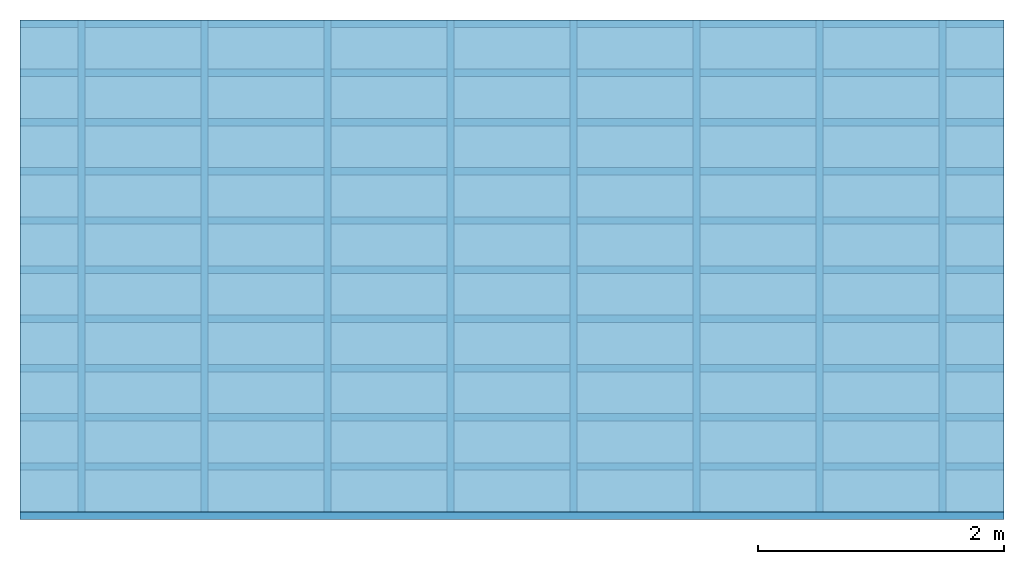
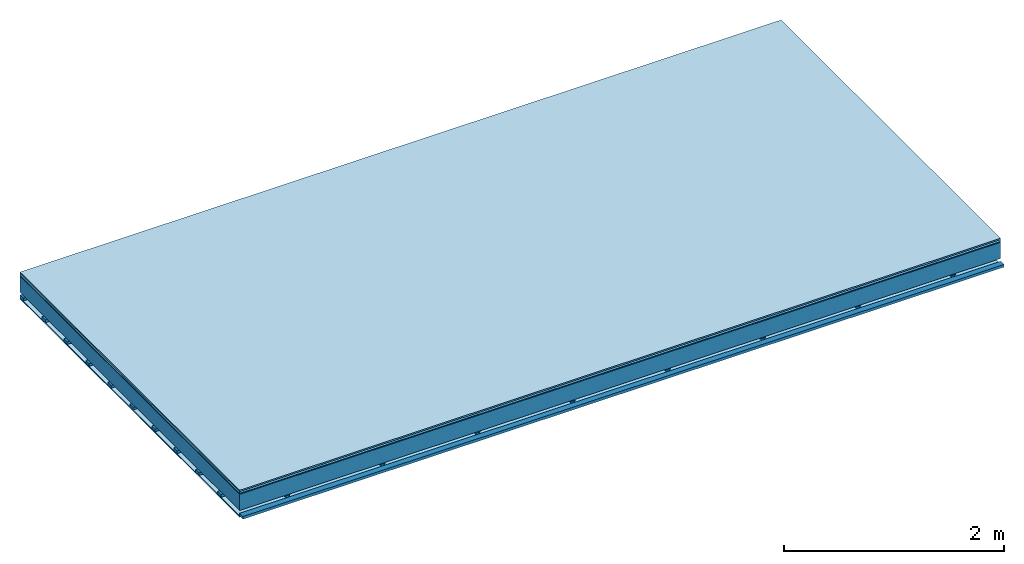
# One storey: 5 plates, 3 members, 1 element without a shape of its own.
"""IFC4 building model written with IfcOpenShell, lengths in metres."""

from ifc_helpers import new_model, si_unit, derived_unit, direction, frame, frame_2d, origin, origin_with_axes, place, context, project, spatial, polyline, rectangle, outline, extrude, material, layer, layer_set, type_object, element, aggregate, save


model = new_model("IFC4")

# Units and contexts
plan_context = context("Plan", 3, precision=1e-05, world=origin(), true_north=direction((0.0, 1.0)))
model_context = context("Model", 3, precision=1e-05, world=origin(), true_north=direction((0.0, 1.0)))
ifc_project = project(units=[si_unit("LENGTHUNIT", "METRE"), derived_unit("SOUNDPRESSUREUNIT", [(si_unit("PRESSUREUNIT", "PASCAL", prefix="MICRO"), 0)]), si_unit("ENERGYUNIT", "JOULE", prefix="MEGA"), si_unit("MASSUNIT", "GRAM", prefix="KILO"), derived_unit("THERMALTRANSMITTANCEUNIT", [(si_unit("POWERUNIT", "WATT"), 1), (si_unit("AREAUNIT", "SQUARE_METRE"), -1), (si_unit("THERMODYNAMICTEMPERATUREUNIT", "KELVIN"), -1)]), derived_unit("AREADENSITYUNIT", [(si_unit("MASSUNIT", "GRAM", prefix="KILO"), 1), (si_unit("AREAUNIT", "SQUARE_METRE"), -1)]), derived_unit("USERDEFINED", [(si_unit("ENERGYUNIT", "JOULE", prefix="MEGA"), 1), (si_unit("AREAUNIT", "SQUARE_METRE"), -1)])], contexts=[plan_context, model_context])

# Site, building, storey
site = spatial("IfcSite", under=ifc_project)
building_placement = place(None, origin())
building = spatial("IfcBuilding", under=site, at=building_placement)
storey_placement = place(building_placement, origin())
storey = spatial("IfcBuildingStorey", under=building, at=storey_placement)

# Slab, members, plates
ifc_material_1 = material(Category="11.013")
ifc_layer_1 = layer(ifc_material_1, 0.015, Name="Flooring")
ifc_material_2 = material(Category="03.007")
ifc_layer_2 = layer(ifc_material_2, 0.02, Name="On-material")
ifc_material_3 = material(Name="Wood fiber generic product", Category="10.009")
ifc_layer_3 = layer(ifc_material_3, 0.01, Name="Impact sound insulation")
ifc_material_4 = material(Name="no composite action")
ifc_layer_4 = layer(ifc_material_4, 0.0, Name="Bond")
ifc_layer_5 = layer(None, 0.18, Name="Supporting structure")
ifc_layer_6 = layer(ifc_material_4, 0.0, Name="Bond")
ifc_layer_7 = layer(None, 0.03, Name="Coupling")
ifc_layer_8 = layer(None, 0.03, Name="Battens / profiles")
ifc_material_5 = material(Name="Plasterboard type A", Category="03.008")
ifc_layer_9 = layer(ifc_material_5, 0.0125, Name="Ceiling covering 1st layer")
ifc_material_6 = material(Category="04.001")
ifc_layer_10 = layer(ifc_material_6, 0.003, Name="Surface / treatment")
ifc_layer_set = layer_set([ifc_layer_1, ifc_layer_2, ifc_layer_3, ifc_layer_4, ifc_layer_5, ifc_layer_6, ifc_layer_7, ifc_layer_8, ifc_layer_9, ifc_layer_10])
slab_type = type_object("IfcSlabType", Name="A2099", PredefinedType="NOTDEFINED", material=ifc_layer_set)
slab_placement = place(None, frame((0.0, 0.0, 0.0), z_axis=(0.0, 0.0, -1.0), x_axis=(1.0, 0.0, 0.0)))
slab = element("IfcSlab", 1, at=slab_placement, inside=storey, type_object=slab_type, material=ifc_layer_set, Name="Slab #1")
ifc_material_7 = material(Name="Solid timber panel")
member_1_placement = place(slab_placement, origin())
member_1 = element("IfcMember", 2, at=member_1_placement, material=ifc_material_7, Name="Supporting structure", context=plan_context, shape_type="SweptSolid", body=[
    extrude(rectangle(XDim=1.0, YDim=0.18, at=frame_2d((0.5, 0.09), x_axis=(1.0, 0.0))), frame((0.0, 4.0, 0.045), z_axis=(0.0, -1.0, 0.0), x_axis=(1.0, 0.0, 0.0)), (0.0, 0.0, 1.0), 4.0),
    extrude(rectangle(XDim=1.0, YDim=0.18, at=frame_2d((0.5, 0.09), x_axis=(1.0, 0.0))), frame((1.0, 4.0, 0.045), z_axis=(0.0, -1.0, 0.0), x_axis=(1.0, 0.0, 0.0)), (0.0, 0.0, 1.0), 4.0),
    extrude(rectangle(XDim=1.0, YDim=0.18, at=frame_2d((0.5, 0.09), x_axis=(1.0, 0.0))), frame((2.0, 4.0, 0.045), z_axis=(0.0, -1.0, 0.0), x_axis=(1.0, 0.0, 0.0)), (0.0, 0.0, 1.0), 4.0),
    extrude(rectangle(XDim=1.0, YDim=0.18, at=frame_2d((0.5, 0.09), x_axis=(1.0, 0.0))), frame((3.0, 4.0, 0.045), z_axis=(0.0, -1.0, 0.0), x_axis=(1.0, 0.0, 0.0)), (0.0, 0.0, 1.0), 4.0),
    extrude(rectangle(XDim=1.0, YDim=0.18, at=frame_2d((0.5, 0.09), x_axis=(1.0, 0.0))), frame((4.0, 4.0, 0.045), z_axis=(0.0, -1.0, 0.0), x_axis=(1.0, 0.0, 0.0)), (0.0, 0.0, 1.0), 4.0),
    extrude(rectangle(XDim=1.0, YDim=0.18, at=frame_2d((0.5, 0.09), x_axis=(1.0, 0.0))), frame((5.0, 4.0, 0.045), z_axis=(0.0, -1.0, 0.0), x_axis=(1.0, 0.0, 0.0)), (0.0, 0.0, 1.0), 4.0),
    extrude(rectangle(XDim=1.0, YDim=0.18, at=frame_2d((0.5, 0.09), x_axis=(1.0, 0.0))), frame((6.0, 4.0, 0.045), z_axis=(0.0, -1.0, 0.0), x_axis=(1.0, 0.0, 0.0)), (0.0, 0.0, 1.0), 4.0),
    extrude(rectangle(XDim=1.0, YDim=0.18, at=frame_2d((0.5, 0.09), x_axis=(1.0, 0.0))), frame((7.0, 4.0, 0.045), z_axis=(0.0, -1.0, 0.0), x_axis=(1.0, 0.0, 0.0)), (0.0, 0.0, 1.0), 4.0),
])
ifc_material_8 = material()
member_2_placement = place(slab_placement, origin())
member_2 = element("IfcMember", 3, at=member_2_placement, material=ifc_material_8, Name="Coupling", context=plan_context, shape_type="SweptSolid", body=[
    extrude(outline(polyline([(0.0, 0.0), (0.06, 0.0), (0.04, 0.02), (0.02, 0.02), (0.0, 0.0)])), frame((0.47, 4.0, 0.235), z_axis=(0.0, -1.0, 0.0), x_axis=(1.0, 0.0, 0.0)), (0.0, 0.0, 1.0), 4.0),
    extrude(outline(polyline([(0.0, 0.0), (0.06, 0.0), (0.04, 0.02), (0.02, 0.02), (0.0, 0.0)])), frame((1.47, 4.0, 0.235), z_axis=(0.0, -1.0, 0.0), x_axis=(1.0, 0.0, 0.0)), (0.0, 0.0, 1.0), 4.0),
    extrude(outline(polyline([(0.0, 0.0), (0.06, 0.0), (0.04, 0.02), (0.02, 0.02), (0.0, 0.0)])), frame((2.47, 4.0, 0.235), z_axis=(0.0, -1.0, 0.0), x_axis=(1.0, 0.0, 0.0)), (0.0, 0.0, 1.0), 4.0),
    extrude(outline(polyline([(0.0, 0.0), (0.06, 0.0), (0.04, 0.02), (0.02, 0.02), (0.0, 0.0)])), frame((3.47, 4.0, 0.235), z_axis=(0.0, -1.0, 0.0), x_axis=(1.0, 0.0, 0.0)), (0.0, 0.0, 1.0), 4.0),
    extrude(outline(polyline([(0.0, 0.0), (0.06, 0.0), (0.04, 0.02), (0.02, 0.02), (0.0, 0.0)])), frame((4.47, 4.0, 0.235), z_axis=(0.0, -1.0, 0.0), x_axis=(1.0, 0.0, 0.0)), (0.0, 0.0, 1.0), 4.0),
    extrude(outline(polyline([(0.0, 0.0), (0.06, 0.0), (0.04, 0.02), (0.02, 0.02), (0.0, 0.0)])), frame((5.47, 4.0, 0.235), z_axis=(0.0, -1.0, 0.0), x_axis=(1.0, 0.0, 0.0)), (0.0, 0.0, 1.0), 4.0),
    extrude(outline(polyline([(0.0, 0.0), (0.06, 0.0), (0.04, 0.02), (0.02, 0.02), (0.0, 0.0)])), frame((6.47, 4.0, 0.235), z_axis=(0.0, -1.0, 0.0), x_axis=(1.0, 0.0, 0.0)), (0.0, 0.0, 1.0), 4.0),
    extrude(outline(polyline([(0.0, 0.0), (0.06, 0.0), (0.04, 0.02), (0.02, 0.02), (0.0, 0.0)])), frame((7.47, 4.0, 0.235), z_axis=(0.0, -1.0, 0.0), x_axis=(1.0, 0.0, 0.0)), (0.0, 0.0, 1.0), 4.0),
])
member_3_placement = place(slab_placement, origin())
member_3 = element("IfcMember", 4, at=member_3_placement, material=ifc_material_8, Name="Battens / profiles", context=plan_context, shape_type="SweptSolid", body=[
    extrude(rectangle(XDim=0.06, YDim=0.03, at=frame_2d((0.03, 0.015), x_axis=(1.0, 0.0))), frame((0.0, 0.0, 0.255), z_axis=(1.0, 0.0, 0.0), x_axis=(0.0, 1.0, 0.0)), (0.0, 0.0, 1.0), 8.0),
    extrude(rectangle(XDim=0.06, YDim=0.03, at=frame_2d((0.03, 0.015), x_axis=(1.0, 0.0))), frame((0.0, 0.4, 0.255), z_axis=(1.0, 0.0, 0.0), x_axis=(0.0, 1.0, 0.0)), (0.0, 0.0, 1.0), 8.0),
    extrude(rectangle(XDim=0.06, YDim=0.03, at=frame_2d((0.03, 0.015), x_axis=(1.0, 0.0))), frame((0.0, 0.8, 0.255), z_axis=(1.0, 0.0, 0.0), x_axis=(0.0, 1.0, 0.0)), (0.0, 0.0, 1.0), 8.0),
    extrude(rectangle(XDim=0.06, YDim=0.03, at=frame_2d((0.03, 0.015), x_axis=(1.0, 0.0))), frame((0.0, 1.2, 0.255), z_axis=(1.0, 0.0, 0.0), x_axis=(0.0, 1.0, 0.0)), (0.0, 0.0, 1.0), 8.0),
    extrude(rectangle(XDim=0.06, YDim=0.03, at=frame_2d((0.03, 0.015), x_axis=(1.0, 0.0))), frame((0.0, 1.6, 0.255), z_axis=(1.0, 0.0, 0.0), x_axis=(0.0, 1.0, 0.0)), (0.0, 0.0, 1.0), 8.0),
    extrude(rectangle(XDim=0.06, YDim=0.03, at=frame_2d((0.03, 0.015), x_axis=(1.0, 0.0))), frame((0.0, 2.0, 0.255), z_axis=(1.0, 0.0, 0.0), x_axis=(0.0, 1.0, 0.0)), (0.0, 0.0, 1.0), 8.0),
    extrude(rectangle(XDim=0.06, YDim=0.03, at=frame_2d((0.03, 0.015), x_axis=(1.0, 0.0))), frame((0.0, 2.4, 0.255), z_axis=(1.0, 0.0, 0.0), x_axis=(0.0, 1.0, 0.0)), (0.0, 0.0, 1.0), 8.0),
    extrude(rectangle(XDim=0.06, YDim=0.03, at=frame_2d((0.03, 0.015), x_axis=(1.0, 0.0))), frame((0.0, 2.8, 0.255), z_axis=(1.0, 0.0, 0.0), x_axis=(0.0, 1.0, 0.0)), (0.0, 0.0, 1.0), 8.0),
    extrude(rectangle(XDim=0.06, YDim=0.03, at=frame_2d((0.03, 0.015), x_axis=(1.0, 0.0))), frame((0.0, 3.2, 0.255), z_axis=(1.0, 0.0, 0.0), x_axis=(0.0, 1.0, 0.0)), (0.0, 0.0, 1.0), 8.0),
    extrude(rectangle(XDim=0.06, YDim=0.03, at=frame_2d((0.03, 0.015), x_axis=(1.0, 0.0))), frame((0.0, 3.6, 0.255), z_axis=(1.0, 0.0, 0.0), x_axis=(0.0, 1.0, 0.0)), (0.0, 0.0, 1.0), 8.0),
    extrude(rectangle(XDim=0.06, YDim=0.03, at=frame_2d((0.03, 0.015), x_axis=(1.0, 0.0))), frame((0.0, 4.0, 0.255), z_axis=(1.0, 0.0, 0.0), x_axis=(0.0, 1.0, 0.0)), (0.0, 0.0, 1.0), 8.0),
])
plate_1_placement = place(slab_placement, origin())
plate_1 = element("IfcPlate", 5, at=plate_1_placement, material=ifc_material_1, Name="Flooring", context=plan_context, shape_type="SweptSolid", body=[
    extrude(rectangle(XDim=8.0, YDim=4.0, at=frame_2d((4.0, 2.0), x_axis=(1.0, 0.0))), origin_with_axes(), (0.0, 0.0, 1.0), 0.015),
])
plate_2_placement = place(slab_placement, origin())
plate_2 = element("IfcPlate", 6, at=plate_2_placement, material=ifc_material_2, Name="On-material", context=plan_context, shape_type="SweptSolid", body=[
    extrude(rectangle(XDim=8.0, YDim=4.0, at=frame_2d((4.0, 2.0), x_axis=(1.0, 0.0))), frame((0.0, 0.0, 0.015), z_axis=(0.0, 0.0, 1.0), x_axis=(1.0, 0.0, 0.0)), (0.0, 0.0, 1.0), 0.02),
])
plate_3_placement = place(slab_placement, origin())
plate_3 = element("IfcPlate", 7, at=plate_3_placement, material=ifc_material_3, Name="Impact sound insulation", context=plan_context, shape_type="SweptSolid", body=[
    extrude(rectangle(XDim=8.0, YDim=4.0, at=frame_2d((4.0, 2.0), x_axis=(1.0, 0.0))), frame((0.0, 0.0, 0.035), z_axis=(0.0, 0.0, 1.0), x_axis=(1.0, 0.0, 0.0)), (0.0, 0.0, 1.0), 0.01),
])
plate_4_placement = place(slab_placement, origin())
plate_4 = element("IfcPlate", 8, at=plate_4_placement, material=ifc_material_5, Name="Ceiling covering 1st layer", context=plan_context, shape_type="SweptSolid", body=[
    extrude(rectangle(XDim=8.0, YDim=4.0, at=frame_2d((4.0, 2.0), x_axis=(1.0, 0.0))), frame((0.0, 0.0, 0.285), z_axis=(0.0, 0.0, 1.0), x_axis=(1.0, 0.0, 0.0)), (0.0, 0.0, 1.0), 0.0125),
])
plate_5_placement = place(slab_placement, origin())
plate_5 = element("IfcPlate", 9, at=plate_5_placement, material=ifc_material_6, Name="Surface / treatment", context=plan_context, shape_type="SweptSolid", body=[
    extrude(rectangle(XDim=8.0, YDim=4.0, at=frame_2d((4.0, 2.0), x_axis=(1.0, 0.0))), frame((0.0, 0.0, 0.2975), z_axis=(0.0, 0.0, 1.0), x_axis=(1.0, 0.0, 0.0)), (0.0, 0.0, 1.0), 0.003),
])
aggregate(slab, [plate_1, plate_2, plate_3, member_1, member_2, member_3, plate_4, plate_5])

save(model, "model.ifc")
